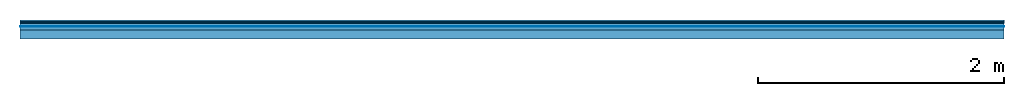
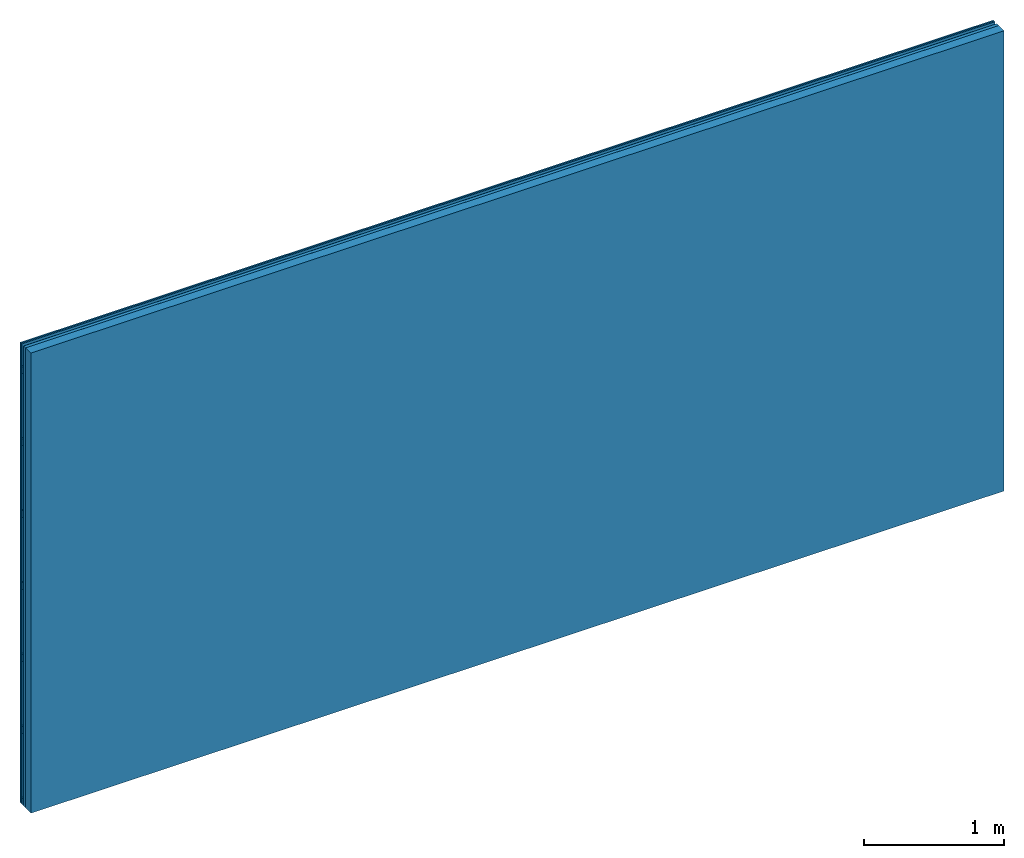
# One storey: 4 plates, 2 members, 1 element without a shape of its own.
"""IFC4 building model written with IfcOpenShell, lengths in metres."""

from ifc_helpers import new_model, si_unit, derived_unit, direction, frame, frame_2d, origin, origin_with_axes, place, context, project, spatial, rectangle, extrude, material, layer, layer_set, type_object, element, aggregate, save


model = new_model("IFC4")

# Units and contexts
plan_context = context("Plan", 3, precision=1e-05, world=origin(), true_north=direction((0.0, 1.0)))
model_context = context("Model", 3, precision=1e-05, world=origin(), true_north=direction((0.0, 1.0)))
ifc_project = project(units=[si_unit("LENGTHUNIT", "METRE"), derived_unit("SOUNDPRESSUREUNIT", [(si_unit("PRESSUREUNIT", "PASCAL", prefix="MICRO"), 0)]), si_unit("ENERGYUNIT", "JOULE", prefix="MEGA"), si_unit("MASSUNIT", "GRAM", prefix="KILO"), derived_unit("THERMALTRANSMITTANCEUNIT", [(si_unit("POWERUNIT", "WATT"), 1), (si_unit("AREAUNIT", "SQUARE_METRE"), -1), (si_unit("THERMODYNAMICTEMPERATUREUNIT", "KELVIN"), -1)]), derived_unit("AREADENSITYUNIT", [(si_unit("MASSUNIT", "GRAM", prefix="KILO"), 1), (si_unit("AREAUNIT", "SQUARE_METRE"), -1)]), derived_unit("USERDEFINED", [(si_unit("ENERGYUNIT", "JOULE", prefix="MEGA"), 1), (si_unit("AREAUNIT", "SQUARE_METRE"), -1)])], contexts=[plan_context, model_context])

# Site, building, storey
site = spatial("IfcSite", under=ifc_project)
building_placement = place(None, origin())
building = spatial("IfcBuilding", under=site, at=building_placement)
storey_placement = place(building_placement, origin())
storey = spatial("IfcBuildingStorey", under=building, at=storey_placement)

# Wall, members, plates
ifc_material_1 = material(Name="joints", Category="04.017")
ifc_layer_1 = layer(ifc_material_1, 0.0, Name="Surface")
ifc_material_2 = material(Name="Rigidur H", Category="03.007")
ifc_layer_2 = layer(ifc_material_2, 0.0125, Name="Cover 2nd layer")
ifc_layer_3 = layer(ifc_material_2, 0.0125, Name="Cover 1st layer")
ifc_layer_4 = layer(None, 0.027, Name="Battens / profiles")
ifc_material_3 = material(Name="Air")
ifc_layer_5 = layer(ifc_material_3, 0.001, Name="Coupling")
ifc_material_4 = material(Category="10.008")
ifc_layer_6 = layer(ifc_material_4, 0.027, Name="Cavity")
ifc_material_5 = material(Name="no composite action")
ifc_layer_7 = layer(ifc_material_5, 0.0, Name="Bond")
ifc_layer_8 = layer(None, 0.075, Name="Support")
ifc_layer_set = layer_set([ifc_layer_1, ifc_layer_2, ifc_layer_3, ifc_layer_4, ifc_layer_5, ifc_layer_6, ifc_layer_7, ifc_layer_8])
wall_type = type_object("IfcWallType", Name="C0474", PredefinedType="NOTDEFINED", material=ifc_layer_set)
wall_placement = place(None, frame((0.0, 0.0, 0.0), z_axis=(0.0, -1.0, 0.0), x_axis=(1.0, 0.0, 0.0)))
wall = element("IfcWall", 1, at=wall_placement, inside=storey, type_object=wall_type, material=ifc_layer_set, Name="Wall #1")
ifc_material_6 = material()
member_1_placement = place(wall_placement, origin())
member_1 = element("IfcMember", 2, at=member_1_placement, material=ifc_material_6, Name="Battens / profiles", context=plan_context, shape_type="SweptSolid", body=[
    extrude(rectangle(XDim=0.06, YDim=0.027, at=frame_2d((0.03, 0.0135), x_axis=(1.0, 0.0))), frame((0.0, 0.0, 0.025), z_axis=(1.0, 0.0, 0.0), x_axis=(0.0, 1.0, 0.0)), (0.0, 0.0, 1.0), 8.0),
    extrude(rectangle(XDim=0.06, YDim=0.027, at=frame_2d((0.03, 0.0135), x_axis=(1.0, 0.0))), frame((0.0, 0.625, 0.025), z_axis=(1.0, 0.0, 0.0), x_axis=(0.0, 1.0, 0.0)), (0.0, 0.0, 1.0), 8.0),
    extrude(rectangle(XDim=0.06, YDim=0.027, at=frame_2d((0.03, 0.0135), x_axis=(1.0, 0.0))), frame((0.0, 1.25, 0.025), z_axis=(1.0, 0.0, 0.0), x_axis=(0.0, 1.0, 0.0)), (0.0, 0.0, 1.0), 8.0),
    extrude(rectangle(XDim=0.06, YDim=0.027, at=frame_2d((0.03, 0.0135), x_axis=(1.0, 0.0))), frame((0.0, 1.875, 0.025), z_axis=(1.0, 0.0, 0.0), x_axis=(0.0, 1.0, 0.0)), (0.0, 0.0, 1.0), 8.0),
    extrude(rectangle(XDim=0.06, YDim=0.027, at=frame_2d((0.03, 0.0135), x_axis=(1.0, 0.0))), frame((0.0, 2.5, 0.025), z_axis=(1.0, 0.0, 0.0), x_axis=(0.0, 1.0, 0.0)), (0.0, 0.0, 1.0), 8.0),
    extrude(rectangle(XDim=0.06, YDim=0.027, at=frame_2d((0.03, 0.0135), x_axis=(1.0, 0.0))), frame((0.0, 3.125, 0.025), z_axis=(1.0, 0.0, 0.0), x_axis=(0.0, 1.0, 0.0)), (0.0, 0.0, 1.0), 8.0),
    extrude(rectangle(XDim=0.06, YDim=0.027, at=frame_2d((0.03, 0.0135), x_axis=(1.0, 0.0))), frame((0.0, 3.75, 0.025), z_axis=(1.0, 0.0, 0.0), x_axis=(0.0, 1.0, 0.0)), (0.0, 0.0, 1.0), 8.0),
])
ifc_material_7 = material(Name="OSB")
member_2_placement = place(wall_placement, origin())
member_2 = element("IfcMember", 3, at=member_2_placement, material=ifc_material_7, Name="Support", context=plan_context, shape_type="SweptSolid", body=[
    extrude(rectangle(XDim=1.0, YDim=0.075, at=frame_2d((0.5, 0.0375), x_axis=(1.0, 0.0))), frame((0.0, 4.0, 0.08), z_axis=(0.0, -1.0, 0.0), x_axis=(1.0, 0.0, 0.0)), (0.0, 0.0, 1.0), 4.0),
    extrude(rectangle(XDim=1.0, YDim=0.075, at=frame_2d((0.5, 0.0375), x_axis=(1.0, 0.0))), frame((1.0, 4.0, 0.08), z_axis=(0.0, -1.0, 0.0), x_axis=(1.0, 0.0, 0.0)), (0.0, 0.0, 1.0), 4.0),
    extrude(rectangle(XDim=1.0, YDim=0.075, at=frame_2d((0.5, 0.0375), x_axis=(1.0, 0.0))), frame((2.0, 4.0, 0.08), z_axis=(0.0, -1.0, 0.0), x_axis=(1.0, 0.0, 0.0)), (0.0, 0.0, 1.0), 4.0),
    extrude(rectangle(XDim=1.0, YDim=0.075, at=frame_2d((0.5, 0.0375), x_axis=(1.0, 0.0))), frame((3.0, 4.0, 0.08), z_axis=(0.0, -1.0, 0.0), x_axis=(1.0, 0.0, 0.0)), (0.0, 0.0, 1.0), 4.0),
    extrude(rectangle(XDim=1.0, YDim=0.075, at=frame_2d((0.5, 0.0375), x_axis=(1.0, 0.0))), frame((4.0, 4.0, 0.08), z_axis=(0.0, -1.0, 0.0), x_axis=(1.0, 0.0, 0.0)), (0.0, 0.0, 1.0), 4.0),
    extrude(rectangle(XDim=1.0, YDim=0.075, at=frame_2d((0.5, 0.0375), x_axis=(1.0, 0.0))), frame((5.0, 4.0, 0.08), z_axis=(0.0, -1.0, 0.0), x_axis=(1.0, 0.0, 0.0)), (0.0, 0.0, 1.0), 4.0),
    extrude(rectangle(XDim=1.0, YDim=0.075, at=frame_2d((0.5, 0.0375), x_axis=(1.0, 0.0))), frame((6.0, 4.0, 0.08), z_axis=(0.0, -1.0, 0.0), x_axis=(1.0, 0.0, 0.0)), (0.0, 0.0, 1.0), 4.0),
    extrude(rectangle(XDim=1.0, YDim=0.075, at=frame_2d((0.5, 0.0375), x_axis=(1.0, 0.0))), frame((7.0, 4.0, 0.08), z_axis=(0.0, -1.0, 0.0), x_axis=(1.0, 0.0, 0.0)), (0.0, 0.0, 1.0), 4.0),
])
plate_1_placement = place(wall_placement, origin())
plate_1 = element("IfcPlate", 4, at=plate_1_placement, material=ifc_material_2, Name="Cover 2nd layer", context=plan_context, shape_type="SweptSolid", body=[
    extrude(rectangle(XDim=8.0, YDim=4.0, at=frame_2d((4.0, 2.0), x_axis=(1.0, 0.0))), origin_with_axes(), (0.0, 0.0, 1.0), 0.0125),
])
plate_2_placement = place(wall_placement, origin())
plate_2 = element("IfcPlate", 5, at=plate_2_placement, material=ifc_material_2, Name="Cover 1st layer", context=plan_context, shape_type="SweptSolid", body=[
    extrude(rectangle(XDim=8.0, YDim=4.0, at=frame_2d((4.0, 2.0), x_axis=(1.0, 0.0))), frame((0.0, 0.0, 0.0125), z_axis=(0.0, 0.0, 1.0), x_axis=(1.0, 0.0, 0.0)), (0.0, 0.0, 1.0), 0.0125),
])
plate_3_placement = place(wall_placement, origin())
plate_3 = element("IfcPlate", 6, at=plate_3_placement, material=ifc_material_3, Name="Coupling", context=plan_context, shape_type="SweptSolid", body=[
    extrude(rectangle(XDim=8.0, YDim=4.0, at=frame_2d((4.0, 2.0), x_axis=(1.0, 0.0))), frame((0.0, 0.0, 0.052), z_axis=(0.0, 0.0, 1.0), x_axis=(1.0, 0.0, 0.0)), (0.0, 0.0, 1.0), 0.001),
])
plate_4_placement = place(wall_placement, origin())
plate_4 = element("IfcPlate", 7, at=plate_4_placement, material=ifc_material_4, Name="Cavity", context=plan_context, shape_type="SweptSolid", body=[
    extrude(rectangle(XDim=8.0, YDim=4.0, at=frame_2d((4.0, 2.0), x_axis=(1.0, 0.0))), frame((0.0, 0.0, 0.053), z_axis=(0.0, 0.0, 1.0), x_axis=(1.0, 0.0, 0.0)), (0.0, 0.0, 1.0), 0.027),
])
aggregate(wall, [plate_1, plate_2, member_1, plate_3, plate_4, member_2])

save(model, "model.ifc")
